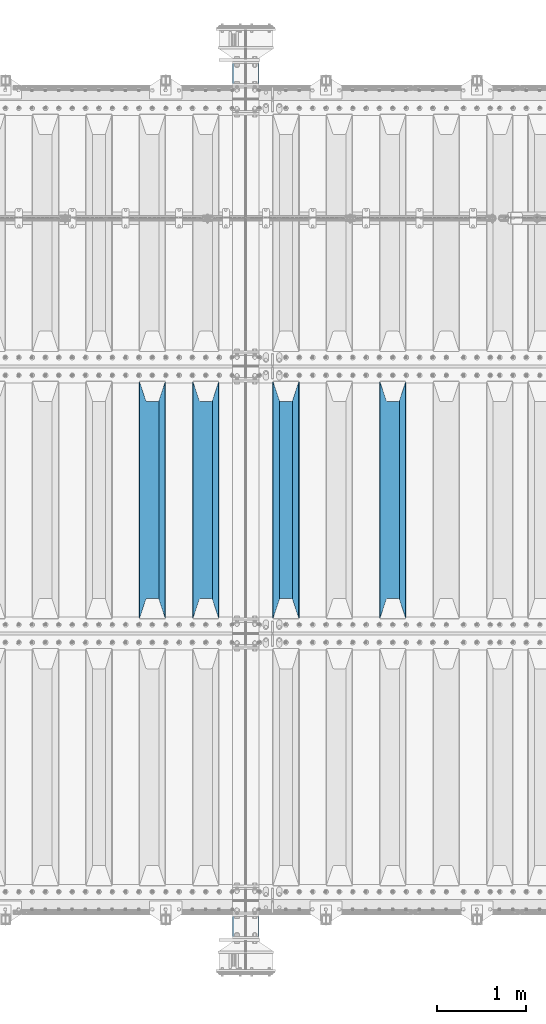
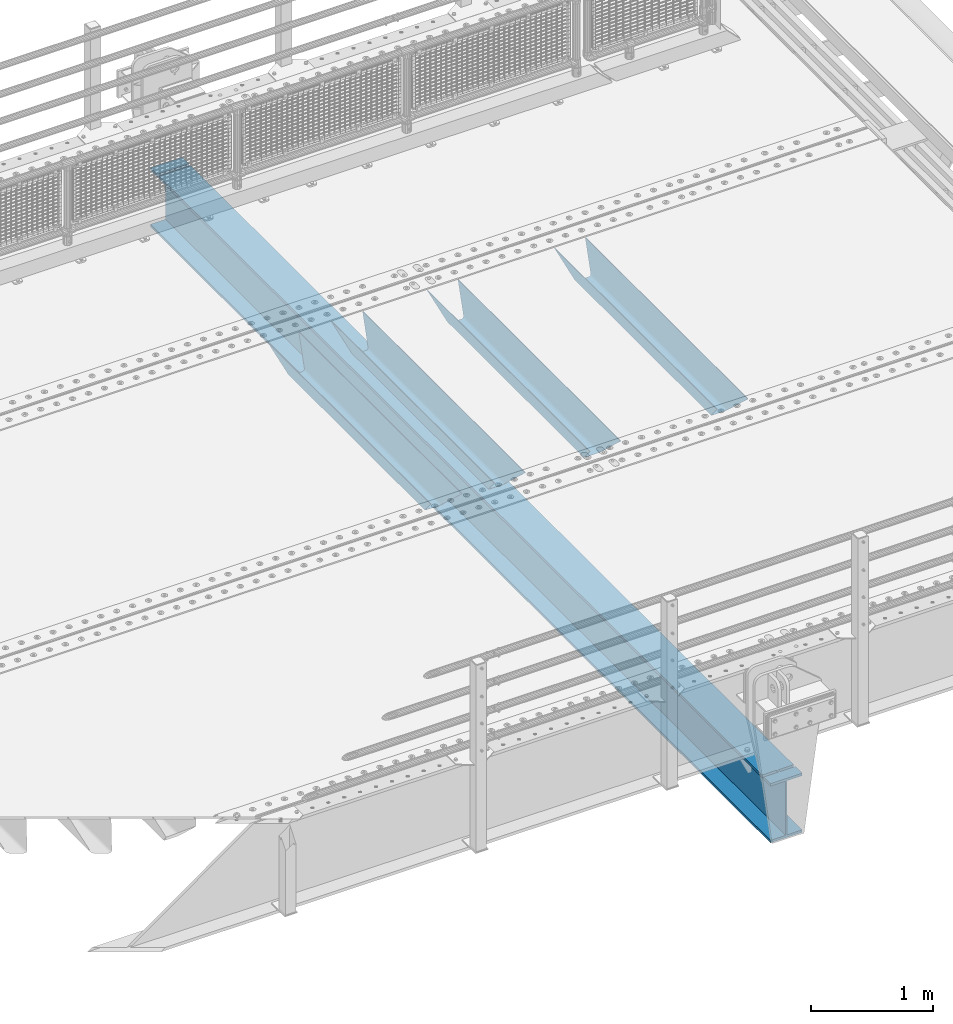
# One storey, part 118 of 247: 5 beams.
"""IFC2X3 building model written with IfcOpenShell, lengths in millimetres."""

from ifc_helpers import new_model, si_unit, frame, origin_with_axes, place, context, subcontext, project, spatial, faceted_brep, material, type_object, element, save


model = new_model("IFC2X3")

# Units and contexts
model_context = context("Model", 3, precision=1e-05, world=origin_with_axes())
body_context = subcontext(model_context, "Body", "Model", "MODEL_VIEW")
ifc_project = project(units=[si_unit("LENGTHUNIT", "METRE", prefix="MILLI"), si_unit("AREAUNIT", "SQUARE_METRE"), si_unit("VOLUMEUNIT", "CUBIC_METRE"), si_unit("MASSUNIT", "GRAM", prefix="KILO"), si_unit("TIMEUNIT", "SECOND"), si_unit("PLANEANGLEUNIT", "RADIAN"), si_unit("SOLIDANGLEUNIT", "STERADIAN"), si_unit("THERMODYNAMICTEMPERATUREUNIT", "DEGREE_CELSIUS"), si_unit("LUMINOUSINTENSITYUNIT", "LUMEN")], contexts=[model_context])

# Site, building, storey
site_placement = place(None, origin_with_axes())
site = spatial("IfcSite", under=ifc_project, at=site_placement, CompositionType="ELEMENT")
building_placement = place(site_placement, origin_with_axes())
building = spatial("IfcBuilding", under=site, at=building_placement, Name="Standard", CompositionType="ELEMENT")
storey_placement = place(building_placement, origin_with_axes())
storey = spatial("IfcBuildingStorey", under=building, at=storey_placement, Name="Undefined", CompositionType="ELEMENT", Elevation=0.0)

# Beams
ifc_material = material(Name="STEEL/S355N")
beam_type_1 = type_object("IfcBeamType", PredefinedType="NOTDEFINED")
beam_1_placement = place(storey_placement, frame((13900.0, 3175.0, -115.0), z_axis=(0.0, 0.0, 1.0), x_axis=(0.0, 1.0, 0.0)))
element("IfcBeam", 1, at=beam_1_placement, inside=storey, type_object=beam_type_1, material=ifc_material, context=body_context, shape_type="Brep", body=[
    faceted_brep([(0.0, 150.0, 115.0), (0.0, 143.689999999999, 115.0), (2650.00000000297, 143.689999999999, 115.0), (2650.00000000297, 150.0, 115.0), (2650.00000000297, 142.059565218402, 110.0000000031), (2650.00000000297, 148.369565218403, 110.0000000031), (2441.90079219208, -80.1103600731112, -98.0992078077845), (2437.7588105432, -77.5672621345584, -102.241189456673), (2434.06523489746, -74.4080125315522, -105.934765102404), (2430.91086095089, -70.710272125576, -109.089139048974), (2428.37322971128, -66.5649389910068, -111.626770288588), (2426.51472138054, -62.0739139532889, -113.485278619323), (2425.38102192091, -57.3475956567672, -114.618978078955), (2424.99999999987, -52.5021667386536, -115.0), (2424.99999999987, 52.5021667386536, -115.0), (2425.38102192091, 57.3475956567672, -114.618978078955), (2426.51472138054, 62.0739139532889, -113.485278619323), (2428.37322971128, 66.5649389910068, -111.626770288588), (2430.91086095089, 70.710272125576, -109.089139048974), (2434.06523489746, 74.4080125315522, -105.934765102404), (2437.7588105432, 77.5672621345584, -102.241189456673), (2441.90079219208, 80.1103600731112, -98.0992078077846), (2446.38936140511, 81.9747917625791, -93.6106385947584), (2448.24948500409, 76.2713538057251, -91.7505149957729), (2444.62967112262, 74.76777986261, -95.3703288772456), (2441.28936334126, 72.7168944282894, -98.710636658607), (2438.31067330438, 70.1691124903846, -101.689326695487), (2435.76682334747, 67.1870637758839, -104.233176652398), (2433.72034654133, 63.8440531834895, -106.279653458539), (2432.22154950041, 60.222258798236, -107.778450499454), (2431.30727574265, 56.4107117849089, -108.692724257221), (2430.99999999987, 52.5031078186876, -109.0), (2430.99999999987, -52.5031078186876, -109.0), (2431.30727574265, -56.4107117849089, -108.692724257221), (2432.22154950041, -60.222258798236, -107.778450499454), (2433.72034654133, -63.8440531834895, -106.279653458539), (2435.76682334747, -67.1870637758839, -104.233176652398), (2438.31067330438, -70.1691124903846, -101.689326695487), (2441.28936334126, -72.7168944282894, -98.7106366586071), (2444.62967112262, -74.76777986261, -95.3703288772457), (2448.24948500409, -76.2713538057251, -91.7505149957729), (2650.00000000297, -142.059565218402, 110.0000000031), (2650.00000000297, -148.369565218403, 110.0000000031), (2446.38936140511, -81.9747917625791, -93.6106385947584), (2650.00000000297, -143.689999999999, 115.0), (2650.00000000297, -150.0, 115.0), (0.0, -143.689999999999, 115.0), (0.0, -150.0, 115.0), (0.0, -148.369565218261, 110.000000002663), (203.610638597422, -81.9747917625791, -93.6106385947584), (208.099207810448, -80.1103600731112, -98.0992078077845), (212.241189459336, -77.5672621345584, -102.241189456673), (215.934765105068, -74.4080125315522, -105.934765102404), (219.089139051637, -70.710272125576, -109.089139048974), (221.626770291251, -66.5649389910068, -111.626770288588), (223.485278621985, -62.0739139532889, -113.485278619323), (224.618978081617, -57.3475956567672, -114.618978078955), (225.000000002663, -52.5021667386536, -115.0), (225.000000002663, 52.5021667386536, -115.0), (224.618978081617, 57.3475956567672, -114.618978078955), (223.485278621985, 62.0739139532889, -113.485278619323), (221.626770291251, 66.5649389910068, -111.626770288588), (219.089139051637, 70.710272125576, -109.089139048974), (215.934765105068, 74.4080125315522, -105.934765102404), (212.241189459336, 77.5672621345584, -102.241189456673), (208.099207810448, 80.1103600731112, -98.0992078077846), (203.610638597422, 81.9747917625791, -93.6106385947584), (0.0, 148.369565218261, 110.000000002663), (0.0, 142.05956521826, 110.000000002663), (201.750514998436, 76.2713538057251, -91.7505149957729), (205.370328879908, 74.76777986261, -95.3703288772456), (208.710636661271, 72.7168944282894, -98.710636658607), (211.68932669815, 70.1691124903846, -101.689326695487), (214.233176655061, 67.1870637758839, -104.233176652398), (216.279653461202, 63.8440531834895, -106.279653458539), (217.778450502117, 60.222258798236, -107.778450499454), (218.692724259885, 56.4107117849089, -108.692724257221), (219.000000002663, 52.5031078186876, -109.0), (219.000000002663, -52.5031078186876, -109.0), (218.692724259885, -56.4107117849089, -108.692724257221), (217.778450502117, -60.222258798236, -107.778450499454), (216.279653461202, -63.8440531834895, -106.279653458539), (214.233176655061, -67.1870637758839, -104.233176652398), (211.68932669815, -70.1691124903846, -101.689326695487), (208.710636661271, -72.7168944282894, -98.7106366586071), (205.370328879908, -74.76777986261, -95.3703288772457), (201.750514998436, -76.2713538057251, -91.7505149957729), (0.0, -142.05956521826, 110.000000002663)], [[[0, 1, 2, 3]], [[3, 2, 4, 5]], [[6, 7, 8, 9, 10, 11, 12, 13, 14, 15, 16, 17, 18, 19, 20, 21, 22, 5, 4, 23, 24, 25, 26, 27, 28, 29, 30, 31, 32, 33, 34, 35, 36, 37, 38, 39, 40, 41, 42, 43]], [[44, 45, 42, 41]], [[46, 47, 45, 44]], [[43, 42, 45, 47, 48, 49]], [[6, 43, 49, 50]], [[7, 6, 50, 51]], [[8, 7, 51, 52]], [[9, 8, 52, 53]], [[10, 9, 53, 54]], [[11, 10, 54, 55]], [[12, 11, 55, 56]], [[13, 12, 56, 57]], [[14, 13, 57, 58]], [[15, 14, 58, 59]], [[16, 15, 59, 60]], [[17, 16, 60, 61]], [[18, 17, 61, 62]], [[19, 18, 62, 63]], [[20, 19, 63, 64]], [[21, 20, 64, 65]], [[22, 21, 65, 66]], [[0, 3, 5, 22, 66, 67]], [[1, 0, 67, 68]], [[23, 4, 2, 1, 68, 69]], [[24, 23, 69, 70]], [[25, 24, 70, 71]], [[26, 25, 71, 72]], [[27, 26, 72, 73]], [[28, 27, 73, 74]], [[29, 28, 74, 75]], [[30, 29, 75, 76]], [[31, 30, 76, 77]], [[32, 31, 77, 78]], [[33, 32, 78, 79]], [[34, 33, 79, 80]], [[35, 34, 80, 81]], [[36, 35, 81, 82]], [[37, 36, 82, 83]], [[38, 37, 83, 84]], [[39, 38, 84, 85]], [[40, 39, 85, 86]], [[46, 44, 41, 40, 86, 87]], [[47, 46, 87, 48]], [[86, 85, 84, 83, 82, 81, 80, 79, 78, 77, 76, 75, 74, 73, 72, 71, 70, 69, 68, 67, 66, 65, 64, 63, 62, 61, 60, 59, 58, 57, 56, 55, 54, 53, 52, 51, 50, 49, 48, 87]]]),
])
beam_2_placement = place(storey_placement, frame((12700.0, 3175.0, -115.0), z_axis=(0.0, 0.0, 1.0), x_axis=(0.0, 1.0, 0.0)))
element("IfcBeam", 2, at=beam_2_placement, inside=storey, type_object=beam_type_1, material=ifc_material, context=body_context, shape_type="Brep", body=[
    faceted_brep([(0.0, 150.0, 115.0), (0.0, 143.689999999999, 115.0), (2650.00000000297, 143.689999999999, 115.0), (2650.00000000297, 150.0, 115.0), (2650.00000000297, 142.059565218402, 110.0000000031), (2650.00000000297, 148.369565218403, 110.0000000031), (2441.90079219208, -80.1103600731112, -98.0992078077845), (2437.7588105432, -77.5672621345584, -102.241189456673), (2434.06523489746, -74.4080125315522, -105.934765102404), (2430.91086095089, -70.710272125576, -109.089139048974), (2428.37322971128, -66.5649389910068, -111.626770288588), (2426.51472138054, -62.0739139532889, -113.485278619323), (2425.38102192091, -57.3475956567672, -114.618978078955), (2424.99999999987, -52.5021667386536, -115.0), (2424.99999999987, 52.5021667386536, -115.0), (2425.38102192091, 57.3475956567672, -114.618978078955), (2426.51472138054, 62.0739139532889, -113.485278619323), (2428.37322971128, 66.5649389910068, -111.626770288588), (2430.91086095089, 70.710272125576, -109.089139048974), (2434.06523489746, 74.4080125315522, -105.934765102404), (2437.7588105432, 77.5672621345584, -102.241189456673), (2441.90079219208, 80.1103600731112, -98.0992078077846), (2446.38936140511, 81.9747917625791, -93.6106385947584), (2448.24948500409, 76.2713538057251, -91.7505149957729), (2444.62967112262, 74.76777986261, -95.3703288772456), (2441.28936334126, 72.7168944282894, -98.710636658607), (2438.31067330438, 70.1691124903846, -101.689326695487), (2435.76682334747, 67.1870637758839, -104.233176652398), (2433.72034654133, 63.8440531834895, -106.279653458539), (2432.22154950041, 60.222258798236, -107.778450499454), (2431.30727574265, 56.4107117849089, -108.692724257221), (2430.99999999987, 52.5031078186876, -109.0), (2430.99999999987, -52.5031078186876, -109.0), (2431.30727574265, -56.4107117849089, -108.692724257221), (2432.22154950041, -60.222258798236, -107.778450499454), (2433.72034654133, -63.8440531834895, -106.279653458539), (2435.76682334747, -67.1870637758839, -104.233176652398), (2438.31067330438, -70.1691124903846, -101.689326695487), (2441.28936334126, -72.7168944282894, -98.7106366586071), (2444.62967112262, -74.76777986261, -95.3703288772457), (2448.24948500409, -76.2713538057251, -91.7505149957729), (2650.00000000297, -142.059565218402, 110.0000000031), (2650.00000000297, -148.369565218403, 110.0000000031), (2446.38936140511, -81.9747917625791, -93.6106385947584), (2650.00000000297, -143.689999999999, 115.0), (2650.00000000297, -150.0, 115.0), (0.0, -143.689999999999, 115.0), (0.0, -150.0, 115.0), (0.0, -148.369565218261, 110.000000002663), (203.610638597422, -81.9747917625791, -93.6106385947584), (208.099207810448, -80.1103600731112, -98.0992078077845), (212.241189459336, -77.5672621345584, -102.241189456673), (215.934765105068, -74.4080125315522, -105.934765102404), (219.089139051637, -70.710272125576, -109.089139048974), (221.626770291251, -66.5649389910068, -111.626770288588), (223.485278621985, -62.0739139532889, -113.485278619323), (224.618978081617, -57.3475956567672, -114.618978078955), (225.000000002663, -52.5021667386536, -115.0), (225.000000002663, 52.5021667386536, -115.0), (224.618978081617, 57.3475956567672, -114.618978078955), (223.485278621985, 62.0739139532889, -113.485278619323), (221.626770291251, 66.5649389910068, -111.626770288588), (219.089139051637, 70.710272125576, -109.089139048974), (215.934765105068, 74.4080125315522, -105.934765102404), (212.241189459336, 77.5672621345584, -102.241189456673), (208.099207810448, 80.1103600731112, -98.0992078077846), (203.610638597422, 81.9747917625791, -93.6106385947584), (0.0, 148.369565218261, 110.000000002663), (0.0, 142.05956521826, 110.000000002663), (201.750514998436, 76.2713538057251, -91.7505149957729), (205.370328879908, 74.76777986261, -95.3703288772456), (208.710636661271, 72.7168944282894, -98.710636658607), (211.68932669815, 70.1691124903846, -101.689326695487), (214.233176655061, 67.1870637758839, -104.233176652398), (216.279653461202, 63.8440531834895, -106.279653458539), (217.778450502117, 60.222258798236, -107.778450499454), (218.692724259885, 56.4107117849089, -108.692724257221), (219.000000002663, 52.5031078186876, -109.0), (219.000000002663, -52.5031078186876, -109.0), (218.692724259885, -56.4107117849089, -108.692724257221), (217.778450502117, -60.222258798236, -107.778450499454), (216.279653461202, -63.8440531834895, -106.279653458539), (214.233176655061, -67.1870637758839, -104.233176652398), (211.68932669815, -70.1691124903846, -101.689326695487), (208.710636661271, -72.7168944282894, -98.7106366586071), (205.370328879908, -74.76777986261, -95.3703288772457), (201.750514998436, -76.2713538057251, -91.7505149957729), (0.0, -142.05956521826, 110.000000002663)], [[[0, 1, 2, 3]], [[3, 2, 4, 5]], [[6, 7, 8, 9, 10, 11, 12, 13, 14, 15, 16, 17, 18, 19, 20, 21, 22, 5, 4, 23, 24, 25, 26, 27, 28, 29, 30, 31, 32, 33, 34, 35, 36, 37, 38, 39, 40, 41, 42, 43]], [[44, 45, 42, 41]], [[46, 47, 45, 44]], [[43, 42, 45, 47, 48, 49]], [[6, 43, 49, 50]], [[7, 6, 50, 51]], [[8, 7, 51, 52]], [[9, 8, 52, 53]], [[10, 9, 53, 54]], [[11, 10, 54, 55]], [[12, 11, 55, 56]], [[13, 12, 56, 57]], [[14, 13, 57, 58]], [[15, 14, 58, 59]], [[16, 15, 59, 60]], [[17, 16, 60, 61]], [[18, 17, 61, 62]], [[19, 18, 62, 63]], [[20, 19, 63, 64]], [[21, 20, 64, 65]], [[22, 21, 65, 66]], [[0, 3, 5, 22, 66, 67]], [[1, 0, 67, 68]], [[23, 4, 2, 1, 68, 69]], [[24, 23, 69, 70]], [[25, 24, 70, 71]], [[26, 25, 71, 72]], [[27, 26, 72, 73]], [[28, 27, 73, 74]], [[29, 28, 74, 75]], [[30, 29, 75, 76]], [[31, 30, 76, 77]], [[32, 31, 77, 78]], [[33, 32, 78, 79]], [[34, 33, 79, 80]], [[35, 34, 80, 81]], [[36, 35, 81, 82]], [[37, 36, 82, 83]], [[38, 37, 83, 84]], [[39, 38, 84, 85]], [[40, 39, 85, 86]], [[46, 44, 41, 40, 86, 87]], [[47, 46, 87, 48]], [[86, 85, 84, 83, 82, 81, 80, 79, 78, 77, 76, 75, 74, 73, 72, 71, 70, 69, 68, 67, 66, 65, 64, 63, 62, 61, 60, 59, 58, 57, 56, 55, 54, 53, 52, 51, 50, 49, 48, 87]]]),
])
beam_3_placement = place(storey_placement, frame((11800.0, 3175.0, -115.0), z_axis=(0.0, 0.0, 1.0), x_axis=(0.0, 1.0, 0.0)))
element("IfcBeam", 3, at=beam_3_placement, inside=storey, type_object=beam_type_1, material=ifc_material, context=body_context, shape_type="Brep", body=[
    faceted_brep([(0.0, 150.0, 115.0), (0.0, 143.689999999999, 115.0), (2650.00000000297, 143.689999999999, 115.0), (2650.00000000297, 150.0, 115.0), (2650.00000000297, 142.059565218402, 110.0000000031), (2650.00000000297, 148.369565218403, 110.0000000031), (2441.90079219208, -80.1103600731112, -98.0992078077845), (2437.7588105432, -77.5672621345584, -102.241189456673), (2434.06523489746, -74.4080125315522, -105.934765102404), (2430.91086095089, -70.710272125576, -109.089139048974), (2428.37322971128, -66.5649389910068, -111.626770288588), (2426.51472138054, -62.0739139532889, -113.485278619323), (2425.38102192091, -57.3475956567672, -114.618978078955), (2424.99999999987, -52.5021667386536, -115.0), (2424.99999999987, 52.5021667386536, -115.0), (2425.38102192091, 57.3475956567672, -114.618978078955), (2426.51472138054, 62.0739139532889, -113.485278619323), (2428.37322971128, 66.5649389910068, -111.626770288588), (2430.91086095089, 70.710272125576, -109.089139048974), (2434.06523489746, 74.4080125315522, -105.934765102404), (2437.7588105432, 77.5672621345584, -102.241189456673), (2441.90079219208, 80.1103600731112, -98.0992078077846), (2446.38936140511, 81.9747917625791, -93.6106385947584), (2448.24948500409, 76.2713538057251, -91.7505149957729), (2444.62967112262, 74.76777986261, -95.3703288772456), (2441.28936334126, 72.7168944282894, -98.710636658607), (2438.31067330438, 70.1691124903846, -101.689326695487), (2435.76682334747, 67.1870637758839, -104.233176652398), (2433.72034654133, 63.8440531834895, -106.279653458539), (2432.22154950041, 60.222258798236, -107.778450499454), (2431.30727574265, 56.4107117849089, -108.692724257221), (2430.99999999987, 52.5031078186876, -109.0), (2430.99999999987, -52.5031078186876, -109.0), (2431.30727574265, -56.4107117849089, -108.692724257221), (2432.22154950041, -60.222258798236, -107.778450499454), (2433.72034654133, -63.8440531834895, -106.279653458539), (2435.76682334747, -67.1870637758839, -104.233176652398), (2438.31067330438, -70.1691124903846, -101.689326695487), (2441.28936334126, -72.7168944282894, -98.7106366586071), (2444.62967112262, -74.76777986261, -95.3703288772457), (2448.24948500409, -76.2713538057251, -91.7505149957729), (2650.00000000297, -142.059565218402, 110.0000000031), (2650.00000000297, -148.369565218403, 110.0000000031), (2446.38936140511, -81.9747917625791, -93.6106385947584), (2650.00000000297, -143.689999999999, 115.0), (2650.00000000297, -150.0, 115.0), (0.0, -143.689999999999, 115.0), (0.0, -150.0, 115.0), (0.0, -148.369565218261, 110.000000002663), (203.610638597422, -81.9747917625791, -93.6106385947584), (208.099207810448, -80.1103600731112, -98.0992078077845), (212.241189459336, -77.5672621345584, -102.241189456673), (215.934765105068, -74.4080125315522, -105.934765102404), (219.089139051637, -70.710272125576, -109.089139048974), (221.626770291251, -66.5649389910068, -111.626770288588), (223.485278621985, -62.0739139532889, -113.485278619323), (224.618978081617, -57.3475956567672, -114.618978078955), (225.000000002663, -52.5021667386536, -115.0), (225.000000002663, 52.5021667386536, -115.0), (224.618978081617, 57.3475956567672, -114.618978078955), (223.485278621985, 62.0739139532889, -113.485278619323), (221.626770291251, 66.5649389910068, -111.626770288588), (219.089139051637, 70.710272125576, -109.089139048974), (215.934765105068, 74.4080125315522, -105.934765102404), (212.241189459336, 77.5672621345584, -102.241189456673), (208.099207810448, 80.1103600731112, -98.0992078077846), (203.610638597422, 81.9747917625791, -93.6106385947584), (0.0, 148.369565218261, 110.000000002663), (0.0, 142.05956521826, 110.000000002663), (201.750514998436, 76.2713538057251, -91.7505149957729), (205.370328879908, 74.76777986261, -95.3703288772456), (208.710636661271, 72.7168944282894, -98.710636658607), (211.68932669815, 70.1691124903846, -101.689326695487), (214.233176655061, 67.1870637758839, -104.233176652398), (216.279653461202, 63.8440531834895, -106.279653458539), (217.778450502117, 60.222258798236, -107.778450499454), (218.692724259885, 56.4107117849089, -108.692724257221), (219.000000002663, 52.5031078186876, -109.0), (219.000000002663, -52.5031078186876, -109.0), (218.692724259885, -56.4107117849089, -108.692724257221), (217.778450502117, -60.222258798236, -107.778450499454), (216.279653461202, -63.8440531834895, -106.279653458539), (214.233176655061, -67.1870637758839, -104.233176652398), (211.68932669815, -70.1691124903846, -101.689326695487), (208.710636661271, -72.7168944282894, -98.7106366586071), (205.370328879908, -74.76777986261, -95.3703288772457), (201.750514998436, -76.2713538057251, -91.7505149957729), (0.0, -142.05956521826, 110.000000002663)], [[[0, 1, 2, 3]], [[3, 2, 4, 5]], [[6, 7, 8, 9, 10, 11, 12, 13, 14, 15, 16, 17, 18, 19, 20, 21, 22, 5, 4, 23, 24, 25, 26, 27, 28, 29, 30, 31, 32, 33, 34, 35, 36, 37, 38, 39, 40, 41, 42, 43]], [[44, 45, 42, 41]], [[46, 47, 45, 44]], [[43, 42, 45, 47, 48, 49]], [[6, 43, 49, 50]], [[7, 6, 50, 51]], [[8, 7, 51, 52]], [[9, 8, 52, 53]], [[10, 9, 53, 54]], [[11, 10, 54, 55]], [[12, 11, 55, 56]], [[13, 12, 56, 57]], [[14, 13, 57, 58]], [[15, 14, 58, 59]], [[16, 15, 59, 60]], [[17, 16, 60, 61]], [[18, 17, 61, 62]], [[19, 18, 62, 63]], [[20, 19, 63, 64]], [[21, 20, 64, 65]], [[22, 21, 65, 66]], [[0, 3, 5, 22, 66, 67]], [[1, 0, 67, 68]], [[23, 4, 2, 1, 68, 69]], [[24, 23, 69, 70]], [[25, 24, 70, 71]], [[26, 25, 71, 72]], [[27, 26, 72, 73]], [[28, 27, 73, 74]], [[29, 28, 74, 75]], [[30, 29, 75, 76]], [[31, 30, 76, 77]], [[32, 31, 77, 78]], [[33, 32, 78, 79]], [[34, 33, 79, 80]], [[35, 34, 80, 81]], [[36, 35, 81, 82]], [[37, 36, 82, 83]], [[38, 37, 83, 84]], [[39, 38, 84, 85]], [[40, 39, 85, 86]], [[46, 44, 41, 40, 86, 87]], [[47, 46, 87, 48]], [[86, 85, 84, 83, 82, 81, 80, 79, 78, 77, 76, 75, 74, 73, 72, 71, 70, 69, 68, 67, 66, 65, 64, 63, 62, 61, 60, 59, 58, 57, 56, 55, 54, 53, 52, 51, 50, 49, 48, 87]]]),
])
beam_4_placement = place(storey_placement, frame((11200.0, 3175.0, -115.0), z_axis=(0.0, 0.0, 1.0), x_axis=(0.0, 1.0, 0.0)))
element("IfcBeam", 4, at=beam_4_placement, inside=storey, type_object=beam_type_1, material=ifc_material, context=body_context, shape_type="Brep", body=[
    faceted_brep([(0.0, 150.0, 115.0), (0.0, 143.689999999999, 115.0), (2650.00000000297, 143.689999999999, 115.0), (2650.00000000297, 150.0, 115.0), (2650.00000000297, 142.059565218402, 110.0000000031), (2650.00000000297, 148.369565218403, 110.0000000031), (2441.90079219208, -80.1103600731112, -98.0992078077845), (2437.7588105432, -77.5672621345584, -102.241189456673), (2434.06523489746, -74.4080125315522, -105.934765102404), (2430.91086095089, -70.710272125576, -109.089139048974), (2428.37322971128, -66.5649389910068, -111.626770288588), (2426.51472138054, -62.0739139532889, -113.485278619323), (2425.38102192091, -57.3475956567672, -114.618978078955), (2424.99999999987, -52.5021667386536, -115.0), (2424.99999999987, 52.5021667386536, -115.0), (2425.38102192091, 57.3475956567672, -114.618978078955), (2426.51472138054, 62.0739139532889, -113.485278619323), (2428.37322971128, 66.5649389910068, -111.626770288588), (2430.91086095089, 70.710272125576, -109.089139048974), (2434.06523489746, 74.4080125315522, -105.934765102404), (2437.7588105432, 77.5672621345584, -102.241189456673), (2441.90079219208, 80.1103600731112, -98.0992078077846), (2446.38936140511, 81.9747917625791, -93.6106385947584), (2448.24948500409, 76.2713538057251, -91.7505149957729), (2444.62967112262, 74.76777986261, -95.3703288772456), (2441.28936334126, 72.7168944282894, -98.710636658607), (2438.31067330438, 70.1691124903846, -101.689326695487), (2435.76682334747, 67.1870637758839, -104.233176652398), (2433.72034654133, 63.8440531834895, -106.279653458539), (2432.22154950041, 60.222258798236, -107.778450499454), (2431.30727574265, 56.4107117849089, -108.692724257221), (2430.99999999987, 52.5031078186876, -109.0), (2430.99999999987, -52.5031078186876, -109.0), (2431.30727574265, -56.4107117849089, -108.692724257221), (2432.22154950041, -60.222258798236, -107.778450499454), (2433.72034654133, -63.8440531834895, -106.279653458539), (2435.76682334747, -67.1870637758839, -104.233176652398), (2438.31067330438, -70.1691124903846, -101.689326695487), (2441.28936334126, -72.7168944282894, -98.7106366586071), (2444.62967112262, -74.76777986261, -95.3703288772457), (2448.24948500409, -76.2713538057251, -91.7505149957729), (2650.00000000297, -142.059565218402, 110.0000000031), (2650.00000000297, -148.369565218403, 110.0000000031), (2446.38936140511, -81.9747917625791, -93.6106385947584), (2650.00000000297, -143.689999999999, 115.0), (2650.00000000297, -150.0, 115.0), (0.0, -143.689999999999, 115.0), (0.0, -150.0, 115.0), (0.0, -148.369565218261, 110.000000002663), (203.610638597422, -81.9747917625791, -93.6106385947584), (208.099207810448, -80.1103600731112, -98.0992078077845), (212.241189459336, -77.5672621345584, -102.241189456673), (215.934765105068, -74.4080125315522, -105.934765102404), (219.089139051637, -70.710272125576, -109.089139048974), (221.626770291251, -66.5649389910068, -111.626770288588), (223.485278621985, -62.0739139532889, -113.485278619323), (224.618978081617, -57.3475956567672, -114.618978078955), (225.000000002663, -52.5021667386536, -115.0), (225.000000002663, 52.5021667386536, -115.0), (224.618978081617, 57.3475956567672, -114.618978078955), (223.485278621985, 62.0739139532889, -113.485278619323), (221.626770291251, 66.5649389910068, -111.626770288588), (219.089139051637, 70.710272125576, -109.089139048974), (215.934765105068, 74.4080125315522, -105.934765102404), (212.241189459336, 77.5672621345584, -102.241189456673), (208.099207810448, 80.1103600731112, -98.0992078077846), (203.610638597422, 81.9747917625791, -93.6106385947584), (0.0, 148.369565218261, 110.000000002663), (0.0, 142.05956521826, 110.000000002663), (201.750514998436, 76.2713538057251, -91.7505149957729), (205.370328879908, 74.76777986261, -95.3703288772456), (208.710636661271, 72.7168944282894, -98.710636658607), (211.68932669815, 70.1691124903846, -101.689326695487), (214.233176655061, 67.1870637758839, -104.233176652398), (216.279653461202, 63.8440531834895, -106.279653458539), (217.778450502117, 60.222258798236, -107.778450499454), (218.692724259885, 56.4107117849089, -108.692724257221), (219.000000002663, 52.5031078186876, -109.0), (219.000000002663, -52.5031078186876, -109.0), (218.692724259885, -56.4107117849089, -108.692724257221), (217.778450502117, -60.222258798236, -107.778450499454), (216.279653461202, -63.8440531834895, -106.279653458539), (214.233176655061, -67.1870637758839, -104.233176652398), (211.68932669815, -70.1691124903846, -101.689326695487), (208.710636661271, -72.7168944282894, -98.7106366586071), (205.370328879908, -74.76777986261, -95.3703288772457), (201.750514998436, -76.2713538057251, -91.7505149957729), (0.0, -142.05956521826, 110.000000002663)], [[[0, 1, 2, 3]], [[3, 2, 4, 5]], [[6, 7, 8, 9, 10, 11, 12, 13, 14, 15, 16, 17, 18, 19, 20, 21, 22, 5, 4, 23, 24, 25, 26, 27, 28, 29, 30, 31, 32, 33, 34, 35, 36, 37, 38, 39, 40, 41, 42, 43]], [[44, 45, 42, 41]], [[46, 47, 45, 44]], [[43, 42, 45, 47, 48, 49]], [[6, 43, 49, 50]], [[7, 6, 50, 51]], [[8, 7, 51, 52]], [[9, 8, 52, 53]], [[10, 9, 53, 54]], [[11, 10, 54, 55]], [[12, 11, 55, 56]], [[13, 12, 56, 57]], [[14, 13, 57, 58]], [[15, 14, 58, 59]], [[16, 15, 59, 60]], [[17, 16, 60, 61]], [[18, 17, 61, 62]], [[19, 18, 62, 63]], [[20, 19, 63, 64]], [[21, 20, 64, 65]], [[22, 21, 65, 66]], [[0, 3, 5, 22, 66, 67]], [[1, 0, 67, 68]], [[23, 4, 2, 1, 68, 69]], [[24, 23, 69, 70]], [[25, 24, 70, 71]], [[26, 25, 71, 72]], [[27, 26, 72, 73]], [[28, 27, 73, 74]], [[29, 28, 74, 75]], [[30, 29, 75, 76]], [[31, 30, 76, 77]], [[32, 31, 77, 78]], [[33, 32, 78, 79]], [[34, 33, 79, 80]], [[35, 34, 80, 81]], [[36, 35, 81, 82]], [[37, 36, 82, 83]], [[38, 37, 83, 84]], [[39, 38, 84, 85]], [[40, 39, 85, 86]], [[46, 44, 41, 40, 86, 87]], [[47, 46, 87, 48]], [[86, 85, 84, 83, 82, 81, 80, 79, 78, 77, 76, 75, 74, 73, 72, 71, 70, 69, 68, 67, 66, 65, 64, 63, 62, 61, 60, 59, 58, 57, 56, 55, 54, 53, 52, 51, 50, 49, 48, 87]]]),
])
beam_type_2 = type_object("IfcBeamType", Name="HEA600", PredefinedType="NOTDEFINED")
beam_5_placement = place(storey_placement, frame((12249.9999999575, -564.999999984413, -1185.000018222), z_axis=(0.0, 0.0, 1.0), x_axis=(0.0, 1.0, 0.0)))
element("IfcBeam", 5, at=beam_5_placement, inside=storey, type_object=beam_type_2, material=ifc_material, ObjectType="HEA600", context=body_context, shape_type="Brep", body=[
    faceted_brep([(9989.99999999952, -150.000000000789, 295.0), (9989.99999999952, -150.0, 270.0), (9989.99999999952, -6.5, 270.0), (9989.99999999952, -6.5, 295.0), (10019.9999999995, -6.5, 270.0), (10019.9999999995, -6.5, 295.0), (10019.9999999995, -150.0, 295.0), (10019.9999999995, -150.0, 270.0), (10129.9999999995, -150.0, 270.0), (10129.9999999995, -150.0, 295.0), (10129.9999999995, -6.5, 270.0), (10129.9999999995, 150.0, 295.0), (10129.9999999995, 150.0, 270.0), (10019.9999999995, 150.0, 270.0), (10019.9999999995, 150.0, 295.0), (140.000000083353, 6.5, 270.0), (140.000000363876, 150.0, 270.0), (9989.99999999952, 150.0, 270.0), (9989.99999999952, 6.5, 270.0), (0.0, -150.0, -295.0), (0.0, 150.0, -295.0), (10129.9999999995, 150.0, -295.0), (10129.9999999995, -150.0, -295.0), (10019.9999999995, -150.0, -270.0), (9989.99999999952, -150.0, -270.0), (139.999999777324, -150.0, -270.0), (109.999999777324, -150.0, -270.0), (0.0, -150.0, -270.0), (10129.9999999995, -150.0, -270.0), (10019.9999999995, -6.5, -270.0), (9989.99999999952, -6.5, -270.0), (140.000000064162, -6.5, -270.0), (110.000000064324, -6.5, -270.0), (0.0, -6.5, -270.0), (10129.9999999995, -6.5, -270.0), (0.0, -150.0, 270.0), (0.0, -6.5, 270.0), (110.000000064324, -6.5, 270.0), (109.999999777324, -150.0, 270.0), (139.999999777324, -150.000000056289, 295.0), (140.000000064162, -6.50000005628863, 295.0), (140.000000064162, -6.5, 270.0), (139.999999777324, -150.0, 270.0), (110.000000064324, -6.49999999628926, 295.0), (109.999999777324, -150.0, 295.0), (0.0, -150.0, 295.0), (0.0, 6.5, 270.0), (0.0, 150.0, 270.0), (110.000000363875, 150.0, 270.0), (110.000000363875, 6.5, 270.0), (0.0, 150.0, 295.0), (0.0, 6.5, -270.0), (0.0, 150.0, -270.0), (110.000000363875, 150.0, 295.0), (110.000000363875, 6.49999994451537, 295.0), (140.000000083354, 6.49999994451537, 295.0), (140.000000363876, 150.0, 295.0), (9989.99999999952, 150.0, 295.0), (9989.99999999952, 6.5, 295.0), (10019.9999999995, 6.5, 295.0), (10019.9999999995, 6.5, 270.0), (10129.9999999995, 6.5, 270.0), (10019.9999999995, 6.5, -270.0), (9989.99999999952, 6.5, -270.0), (140.000000083353, 6.5, -270.0), (110.000000363875, 6.5, -270.0), (10129.9999999995, 6.5, -270.0), (10019.9999999995, 150.0, -270.0), (9989.99999999952, 150.0, -270.0), (140.000000363876, 150.0, -270.0), (110.000000363875, 150.0, -270.0), (10129.9999999995, 150.0, -270.0)], [[[0, 1, 2, 3]], [[3, 2, 4, 5]], [[6, 5, 4, 7]], [[8, 9, 6, 7]], [[10, 8, 7, 4]], [[11, 12, 13, 14]], [[15, 16, 17, 18]], [[19, 20, 21, 22]], [[23, 24, 25, 26, 27, 19, 22, 28]], [[29, 30, 31, 32, 33, 27, 26, 25, 24, 23, 28, 34]], [[35, 36, 37, 38]], [[39, 40, 41, 42]], [[43, 37, 41, 40]], [[44, 38, 37, 43]], [[45, 35, 38, 44]], [[46, 47, 48, 49]], [[19, 27, 33, 36, 35, 45, 50, 47, 46, 51, 52, 20]], [[47, 50, 53, 48]], [[54, 49, 48, 53]], [[55, 15, 49, 54]], [[56, 16, 15, 55]], [[16, 56, 57, 17]], [[58, 18, 17, 57]], [[59, 60, 18, 58]], [[14, 13, 60, 59]], [[12, 61, 60, 13]], [[62, 63, 64, 65, 51, 46, 49, 15, 18, 60, 61, 66]], [[67, 68, 69, 70, 52, 51, 65, 64, 63, 62, 66, 71]], [[20, 52, 70, 69, 68, 67, 71, 21]], [[66, 61, 12, 11, 9, 8, 10, 34, 28, 22, 21, 71]], [[4, 2, 41, 37, 36, 33, 32, 31, 30, 29, 34, 10]], [[42, 41, 2, 1]], [[39, 42, 1, 0]], [[9, 11, 14, 59, 58, 57, 56, 55, 54, 53, 50, 45, 44, 43, 40, 39, 0, 3, 5, 6]]]),
])

save(model, "model.ifc")
